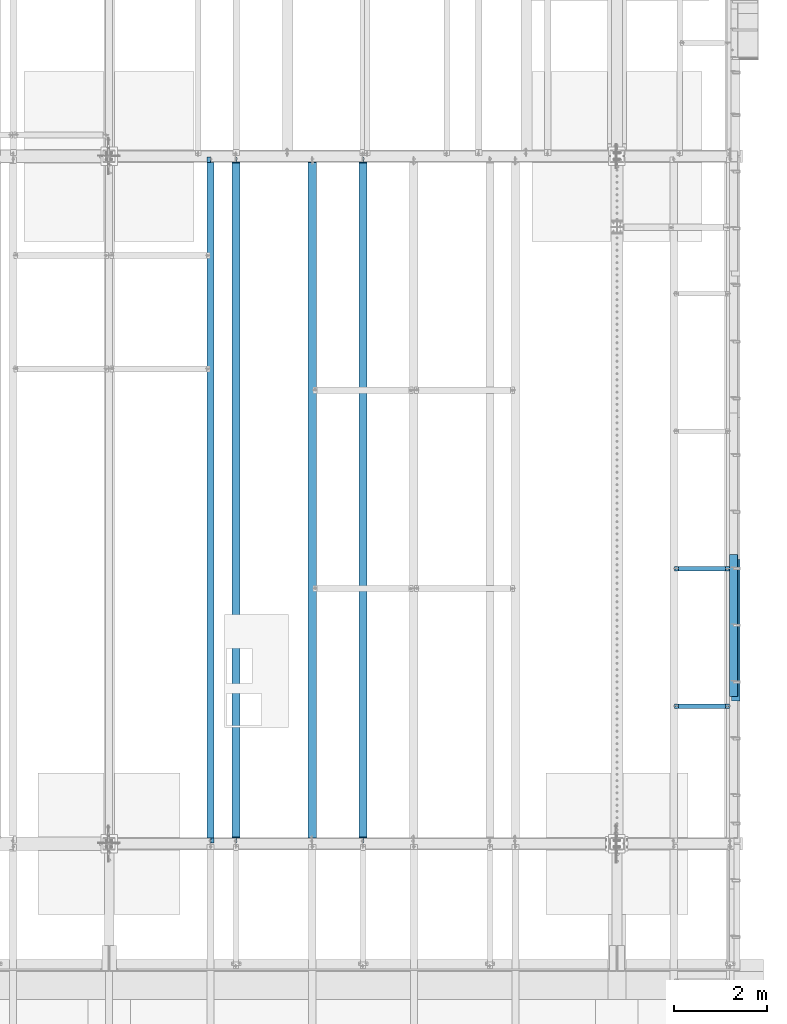
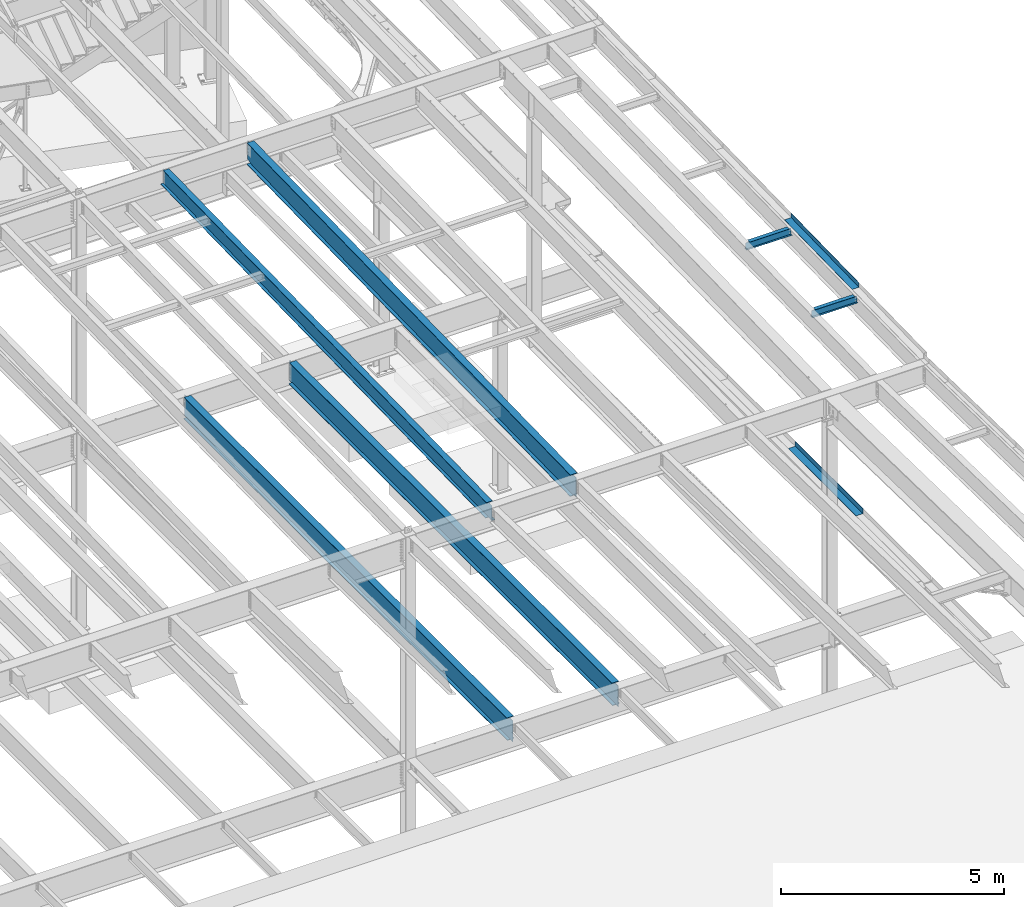
# One storey, part 1120 of 1763: 8 beams, 8 elements without a shape of their own.
"""IFC2X3 building model written with IfcOpenShell, lengths in millimetres."""

from ifc_helpers import new_model, si_unit, frame, origin_with_axes, place, context, subcontext, project, spatial, faceted_brep, material, type_object, element, aggregate, save


model = new_model("IFC2X3")

# Units and contexts
model_context = context("Model", 3, precision=1e-05, world=origin_with_axes())
body_context = subcontext(model_context, "Body", "Model", "MODEL_VIEW")
ifc_project = project(units=[si_unit("LENGTHUNIT", "METRE", prefix="MILLI"), si_unit("AREAUNIT", "SQUARE_METRE"), si_unit("VOLUMEUNIT", "CUBIC_METRE"), si_unit("MASSUNIT", "GRAM", prefix="KILO"), si_unit("TIMEUNIT", "SECOND"), si_unit("PLANEANGLEUNIT", "RADIAN"), si_unit("SOLIDANGLEUNIT", "STERADIAN"), si_unit("THERMODYNAMICTEMPERATUREUNIT", "DEGREE_CELSIUS"), si_unit("LUMINOUSINTENSITYUNIT", "LUMEN")], contexts=[model_context])

# Site, building, storey
site_placement = place(None, origin_with_axes())
site = spatial("IfcSite", under=ifc_project, at=site_placement, CompositionType="ELEMENT")
building_placement = place(site_placement, origin_with_axes())
building = spatial("IfcBuilding", under=site, at=building_placement, Name="Undefined", CompositionType="ELEMENT")
storey_placement = place(building_placement, origin_with_axes())
storey = spatial("IfcBuildingStorey", under=building, at=storey_placement, Name="Undefined", CompositionType="ELEMENT", Elevation=0.0)

# Assembly, beam
assembly_1_placement = place(storey_placement, origin_with_axes())
assembly_1 = element("IfcElementAssembly", 1, at=assembly_1_placement, inside=storey, Name="BEAM", AssemblyPlace="NOTDEFINED", PredefinedType="RIGID_FRAME")
ifc_material_1 = material(Name="STEEL/A992")
beam_type_1 = type_object("IfcBeamType", Name="W8X10", PredefinedType="NOTDEFINED")
beam_1_placement = place(assembly_1_placement, frame((-22808.6484080275, 32979.36, 11251.4577057883), z_axis=(0.0, 0.0, 1.0), x_axis=(1.0, 0.0, 0.0)))
beam_1 = element("IfcBeam", 2, at=beam_1_placement, type_object=beam_type_1, material=ifc_material_1, Name="BEAM", ObjectType="W8X10", context=body_context, shape_type="Brep", body=[
    faceted_brep([(1119.19526367187, -50.7999999999993, 100.012500000001), (1119.19526367187, -50.7999999999993, 95.25), (1119.19526367187, -2.38124999999854, 95.25), (1119.19526367187, -2.38124999999854, 83.877501483119), (1119.19526367187, 2.38124999999854, 83.877501483119), (1119.19526367187, 2.38124999999854, 95.25), (1119.19526367187, 50.7999999999993, 95.25), (1119.19526367187, 50.7999999999993, 100.012500000001), (1120.16199359446, -2.38124999999854, 79.0174219650726), (1120.16199359446, 2.38124999999854, 79.0174219650726), (1122.91500749494, -2.38124999999854, 74.8972454969189), (1122.91500749494, 2.38124999999854, 74.8972454969189), (1127.03518396309, -2.38124999999854, 72.1442315964414), (1127.03518396309, 2.38124999999854, 72.1442315964414), (1131.89526348114, -2.38124999999854, 71.1775016738538), (1131.89526348114, 2.38124999999854, 71.1775016738538), (1201.74526367187, -2.38124999999854, 71.1775016738538), (1201.74526367187, 2.38124999999854, 71.1775016738538), (100.012500000012, -50.7999999999993, 100.012500000001), (100.012500000012, 50.7999999999993, 100.012500000001), (100.012500000012, 50.7999999999993, 95.25), (100.012500000012, 2.38124999999854, 95.25), (100.012500000012, 2.38124999999854, 83.877501483119), (100.012500000012, -2.38124999999854, 83.877501483119), (100.012500000012, -2.38124999999854, 95.25), (100.012500000012, -50.7999999999993, 95.25), (99.0457700774241, 2.38124999999854, 79.0174219650726), (99.0457700774241, -2.38124999999854, 79.0174219650726), (96.2927561769466, 2.38124999999854, 74.8972454969189), (96.2927561769466, -2.38124999999854, 74.8972454969189), (92.1725797087929, 2.38124999999854, 72.1442315964414), (92.1725797087929, -2.38124999999854, 72.1442315964414), (87.3125001907465, 2.38124999999854, 71.1775016738538), (87.3125001907465, -2.38124999999854, 71.1775016738538), (17.4625000000015, 2.38124999999854, 71.1775016738538), (17.4625000000015, -2.38124999999854, 71.1775016738538), (17.462499935149, 2.38124999999854, -95.25), (17.4625000000015, 50.7999999999993, -95.25), (17.4625000000015, 50.7999999999993, -100.012500000001), (17.4624996160601, -50.8000000000029, -100.012500000001), (17.4624996160601, -50.8000000000029, -95.25), (17.4624999065727, -2.38124999999854, -95.25), (1201.74526367187, 2.38124999999854, -95.25), (1201.74526367187, 50.7999999999993, -95.25), (1201.74526367187, 50.7999999999993, -100.012500000001), (1201.74526367187, -50.7999999999993, -100.012500000001), (1201.74526367187, -50.7999999999993, -95.25), (1201.74526367187, -2.38124999999854, -95.25)], [[[0, 1, 2, 3, 4, 5, 6, 7]], [[8, 9, 4, 3]], [[10, 11, 9, 8]], [[12, 13, 11, 10]], [[14, 15, 13, 12]], [[16, 17, 15, 14]], [[18, 19, 20, 21, 22, 23, 24, 25]], [[23, 22, 26, 27]], [[27, 26, 28, 29]], [[29, 28, 30, 31]], [[31, 30, 32, 33]], [[33, 32, 34, 35]], [[36, 37, 38, 39, 40, 41, 35, 34]], [[37, 36, 42, 43]], [[38, 37, 43, 44]], [[39, 38, 44, 45]], [[40, 39, 45, 46]], [[41, 40, 46, 47]], [[12, 10, 8, 3, 2, 24, 23, 27, 29, 31, 33, 35, 41, 47, 16, 14]], [[25, 24, 2, 1]], [[18, 25, 1, 0]], [[19, 18, 0, 7]], [[20, 19, 7, 6]], [[21, 20, 6, 5]], [[42, 36, 34, 32, 30, 28, 26, 22, 21, 5, 4, 9, 11, 13, 15, 17]], [[47, 46, 45, 44, 43, 42, 17, 16]]]),
])
aggregate(assembly_1, [beam_1])

assembly_2_placement = place(storey_placement, origin_with_axes())
assembly_2 = element("IfcElementAssembly", 3, at=assembly_2_placement, inside=storey, Name="BEAM", AssemblyPlace="NOTDEFINED", PredefinedType="RIGID_FRAME")
beam_2_placement = place(assembly_2_placement, frame((-22808.6484080275, 35935.92, 11312.6279115835), z_axis=(0.0, 0.0, 1.0), x_axis=(1.0, 0.0, 0.0)))
beam_2 = element("IfcBeam", 4, at=beam_2_placement, type_object=beam_type_1, material=ifc_material_1, Name="BEAM", ObjectType="W8X10", context=body_context, shape_type="Brep", body=[
    faceted_brep([(1119.19526367187, -50.7999999999993, 100.012500000001), (1119.19526367187, -50.7999999999993, 95.25), (1119.19526367187, -2.38124999999854, 95.25), (1119.19526367187, -2.38124999999854, 83.877501483119), (1119.19526367187, 2.38124999999854, 83.877501483119), (1119.19526367187, 2.38124999999854, 95.25), (1119.19526367187, 50.7999999999993, 95.25), (1119.19526367187, 50.7999999999993, 100.012500000001), (1120.16199359446, -2.38124999999854, 79.0174219650726), (1120.16199359446, 2.38124999999854, 79.0174219650726), (1122.91500749494, -2.38124999999854, 74.8972454969189), (1122.91500749494, 2.38124999999854, 74.8972454969189), (1127.03518396309, -2.38124999999854, 72.1442315964414), (1127.03518396309, 2.38124999999854, 72.1442315964414), (1131.89526348114, -2.38124999999854, 71.1775016738538), (1131.89526348114, 2.38124999999854, 71.1775016738538), (1201.74526367187, -2.38124999999854, 71.1775016738538), (1201.74526367187, 2.38124999999854, 71.1775016738538), (100.012500000012, -50.7999999999993, 100.012500000001), (100.012500000012, 50.7999999999993, 100.012500000001), (100.012500000012, 50.7999999999993, 95.25), (100.012500000012, 2.38124999999854, 95.25), (100.012500000012, 2.38124999999854, 83.877501483119), (100.012500000012, -2.38124999999854, 83.877501483119), (100.012500000012, -2.38124999999854, 95.25), (100.012500000012, -50.7999999999993, 95.25), (99.0457700774241, 2.38124999999854, 79.0174219650726), (99.0457700774241, -2.38124999999854, 79.0174219650726), (96.2927561769466, 2.38124999999854, 74.8972454969189), (96.2927561769466, -2.38124999999854, 74.8972454969189), (92.1725797087929, 2.38124999999854, 72.1442315964414), (92.1725797087929, -2.38124999999854, 72.1442315964414), (87.3125001907465, 2.38124999999854, 71.1775016738538), (87.3125001907465, -2.38124999999854, 71.1775016738538), (17.4625000000015, 2.38124999999854, 71.1775016738538), (17.4625000000015, -2.38124999999854, 71.1775016738538), (17.462499935149, 2.38124999999854, -95.25), (17.4625000000015, 50.7999999999993, -95.25), (17.4625000000015, 50.7999999999993, -100.012500000001), (17.4624996160601, -50.8000000000029, -100.012500000001), (17.4624996160601, -50.8000000000029, -95.25), (17.4624999065727, -2.38124999999854, -95.25), (1201.74526367187, 2.38124999999854, -95.25), (1201.74526367187, 50.7999999999993, -95.25), (1201.74526367187, 50.7999999999993, -100.012500000001), (1201.74526367187, -50.7999999999993, -100.012500000001), (1201.74526367187, -50.7999999999993, -95.25), (1201.74526367187, -2.38124999999854, -95.25)], [[[0, 1, 2, 3, 4, 5, 6, 7]], [[8, 9, 4, 3]], [[10, 11, 9, 8]], [[12, 13, 11, 10]], [[14, 15, 13, 12]], [[16, 17, 15, 14]], [[18, 19, 20, 21, 22, 23, 24, 25]], [[23, 22, 26, 27]], [[27, 26, 28, 29]], [[29, 28, 30, 31]], [[31, 30, 32, 33]], [[33, 32, 34, 35]], [[36, 37, 38, 39, 40, 41, 35, 34]], [[37, 36, 42, 43]], [[38, 37, 43, 44]], [[39, 38, 44, 45]], [[40, 39, 45, 46]], [[41, 40, 46, 47]], [[12, 10, 8, 3, 2, 24, 23, 27, 29, 31, 33, 35, 41, 47, 16, 14]], [[25, 24, 2, 1]], [[18, 25, 1, 0]], [[19, 18, 0, 7]], [[20, 19, 7, 6]], [[21, 20, 6, 5]], [[42, 36, 34, 32, 30, 28, 26, 22, 21, 5, 4, 9, 11, 13, 15, 17]], [[47, 46, 45, 44, 43, 42, 17, 16]]]),
])
aggregate(assembly_2, [beam_2])

assembly_3_placement = place(storey_placement, origin_with_axes())
assembly_3 = element("IfcElementAssembly", 5, at=assembly_3_placement, inside=storey, Name="BEAM", AssemblyPlace="NOTDEFINED", PredefinedType="RIGID_FRAME")
ifc_material_2 = material(Name="STEEL/A36")
beam_type_2 = type_object("IfcBeamType", PredefinedType="NOTDEFINED")
beam_3_placement = place(assembly_3_placement, frame((-21564.0372736984, 34613.85, 5199.0625), z_axis=(0.0, -1.0, 0.0), x_axis=(1.0, 0.0, 0.0)))
beam_3 = element("IfcBeam", 6, at=beam_3_placement, type_object=beam_type_2, material=ifc_material_2, Name="BENT_PLATE", context=body_context, shape_type="Brep", body=[
    faceted_brep([(0.0, -4.76249999999982, -1524.0), (0.0, -4.76249999999982, 1524.0), (0.0, 4.76249999999982, 1524.0), (0.0, 4.76249999999982, -1524.0), (177.799996948241, 4.76249999999982, 1524.0), (177.799996948241, 4.76249999999982, -1524.0), (187.324996948242, -4.76249999999982, -1524.0), (187.324996948242, -4.76249999999982, 1524.0), (177.799996948241, 134.937496948242, 1524.0), (177.799996948241, 134.937496948242, -1524.0), (187.324996948242, 134.937496948242, 1524.0), (187.324996948242, 134.937496948242, -1524.0)], [[[0, 1, 2, 3]], [[3, 2, 4, 5]], [[1, 0, 6, 7]], [[5, 4, 8, 9]], [[4, 2, 1, 7, 10, 8]], [[7, 6, 11, 10]], [[6, 0, 3, 5, 9, 11]], [[10, 11, 9, 8]]]),
])
aggregate(assembly_3, [beam_3])

assembly_4_placement = place(storey_placement, origin_with_axes())
assembly_4 = element("IfcElementAssembly", 7, at=assembly_4_placement, inside=storey, Name="BEAM", AssemblyPlace="NOTDEFINED", PredefinedType="RIGID_FRAME")
beam_type_3 = type_object("IfcBeamType", PredefinedType="NOTDEFINED")
beam_4_placement = place(assembly_4_placement, frame((-21608.4906443556, 34715.4514095832, 11390.5650172283), z_axis=(0.0, -0.999786037781472, -0.0206852279954809), x_axis=(1.0, 0.0, 0.0)))
beam_4 = element("IfcBeam", 8, at=beam_4_placement, type_object=beam_type_3, material=ifc_material_2, Name="BENT_PLATE", context=body_context, shape_type="Brep", body=[
    faceted_brep([(0.0, -3.17499999999927, -1523.99999999999), (0.0, -3.17499999999927, 1524.0), (0.0, 3.17499999999927, 1524.0), (0.0, 3.17499999999927, -1523.99999999999), (174.625006103754, 3.17500000029031, 1523.99999999885), (174.625006103754, 3.17499999971005, -1523.99999999885), (180.975006103752, -3.17500000028485, -1523.99999999885), (180.975006103752, -3.17499999970642, 1523.99999999885), (174.625006103754, 123.824997298747, 1523.99999999882), (174.625006103754, 123.824997298168, -1523.99999999888), (180.975006103752, 123.824997298747, 1523.99999999882), (180.975006103752, 123.824997298168, -1523.99999999888)], [[[0, 1, 2, 3]], [[3, 2, 4, 5]], [[1, 0, 6, 7]], [[5, 4, 8, 9]], [[4, 2, 1, 7, 10, 8]], [[7, 6, 11, 10]], [[6, 0, 3, 5, 9, 11]], [[10, 11, 9, 8]]]),
])
aggregate(assembly_4, [beam_4])

assembly_5_placement = place(storey_placement, origin_with_axes())
assembly_5 = element("IfcElementAssembly", 9, at=assembly_5_placement, inside=storey, Name="BEAM", AssemblyPlace="NOTDEFINED", PredefinedType="RIGID_FRAME")
beam_type_4 = type_object("IfcBeamType", Name="W18X35", PredefinedType="NOTDEFINED")
beam_5_placement = place(assembly_5_placement, frame((-32765.4372736984, 30027.4629676506, 11064.9232324289), z_axis=(0.0, -0.0206852279954837, 0.999786037781472), x_axis=(0.0, 0.999786037781472, 0.0206852279954825)))
beam_5 = element("IfcBeam", 10, at=beam_5_placement, type_object=beam_type_4, material=ifc_material_1, Name="BEAM", ObjectType="W18X35", context=body_context, shape_type="Brep", body=[
    faceted_brep([(159.64619625721, 4.26867060484437, -214.312499999869), (159.646196257192, 4.26882632721026, -225.424999999859), (8.93222613264516, 4.26881713373223, -225.424999999832), (9.1621399216092, 4.26866142537256, -214.31249999984), (159.646191869044, 76.2000000000007, -214.312499999867), (159.646191869044, 76.2000000000007, -225.424999999861), (127.896191565305, -3.96875, 199.765001487393), (127.896191565305, 3.96874999999636, 199.765001487393), (126.929461642718, 3.96874999999636, 194.904921969359), (126.929461642718, -3.96875, 194.904921969359), (124.176447742248, 3.96874999999636, 190.784745501214), (124.176447742248, -3.96875, 190.784745501214), (120.056271274101, 3.96874999999636, 188.031731600742), (120.056271274101, -3.96875, 188.031731600742), (115.196191756069, 3.96874999999636, 187.065001678158), (115.196191756069, -3.96875, 187.065001678158), (17.4665018757805, 3.96874999999636, 187.065001678178), (17.4665018757805, -3.96875, 187.065001678178), (9.1621399216092, -3.96875, -214.31249999984), (14758.6054633429, -3.96875, -214.31250000265), (14766.9098252963, -3.96875, 187.065001635985), (14661.4395147718, -3.96875, 187.065001636005), (14656.5794352537, -3.96875, 188.031731558593), (14652.4592587856, -3.96875, 190.784745459065), (14649.7062448851, -3.96875, 194.904921927209), (14648.7395149625, -3.96875, 199.765001445245), (14648.7395149625, -3.96875, 214.31249999705), (127.896191565309, -3.96875, 214.312499999814), (9.1621399216092, -76.2000000000007, -214.31249999984), (14616.9895144523, -76.2000000000007, -214.312500002621), (14616.9895071152, -4.2686706132954, -214.312500002623), (14758.6054633429, -4.26865616819123, -214.31250000265), (8.93222613264516, -76.2000000000007, -225.424999999832), (14616.9895144523, -76.2000000000007, -225.425000002613), (14616.9895071152, -4.2688263315431, -225.425000002615), (14758.3755495539, -4.26881190989661, -225.42500000264), (14758.3755495539, 76.2000000000007, -225.42500000264), (14758.6054633429, 76.2000000000007, -214.31250000265), (14758.6054633429, 3.96874999999636, -214.31250000265), (14766.9098252963, 3.96874999999636, 187.065001635985), (14661.4395147718, 3.96874999999636, 187.065001636005), (14656.5794352537, 3.96874999999636, 188.031731558593), (14652.4592587856, 3.96874999999636, 190.784745459065), (14649.7062448851, 3.96874999999636, 194.904921927209), (14648.7395149625, 3.96874999999636, 199.765001445245), (14648.7395149625, -76.2000000000007, 225.424999997042), (14648.7395149625, -76.2000000000007, 214.31249999705), (14648.7395149625, 3.96874999999636, 214.31249999705), (14648.7395149625, 76.2000000000007, 214.31249999705), (14648.7395149625, 76.2000000000007, 225.424999997042), (127.896191565309, 3.96874999999636, 214.312499999814), (127.896191565309, 76.2000000000007, 214.312499999814), (127.896191565309, 76.2000000000007, 225.424999999805), (127.896191565309, -76.2000000000007, 225.424999999805), (127.896191565309, -76.2000000000007, 214.312499999814), (9.1621399216092, 3.96874999999636, -214.31249999984)], [[[0, 1, 2, 3]], [[4, 5, 1, 0]], [[6, 7, 8, 9]], [[9, 8, 10, 11]], [[11, 10, 12, 13]], [[13, 12, 14, 15]], [[15, 14, 16, 17]], [[9, 11, 13, 15, 17, 18, 19, 20, 21, 22, 23, 24, 25, 26, 27, 6]], [[19, 18, 28, 29, 30, 31]], [[28, 32, 33, 29]], [[29, 33, 34, 30]], [[31, 30, 34, 35]], [[36, 37, 38, 39, 20, 19, 31, 35]], [[20, 39, 40, 21]], [[21, 40, 41, 22]], [[22, 41, 42, 23]], [[23, 42, 43, 24]], [[24, 43, 44, 25]], [[45, 46, 26, 25, 44, 47, 48, 49]], [[48, 47, 50, 51]], [[49, 48, 51, 52]], [[45, 49, 52, 53]], [[46, 45, 53, 54]], [[26, 46, 54, 27]], [[53, 52, 51, 50, 7, 6, 27, 54]], [[47, 44, 43, 42, 41, 40, 39, 38, 55, 16, 14, 12, 10, 8, 7, 50]], [[32, 28, 18, 17, 16, 55, 3, 2]], [[36, 35, 34, 33, 32, 2, 1, 5]], [[37, 36, 5, 4]], [[55, 38, 37, 4, 0, 3]]]),
])
aggregate(assembly_5, [beam_5])

assembly_6_placement = place(storey_placement, origin_with_axes())
assembly_6 = element("IfcElementAssembly", 11, at=assembly_6_placement, inside=storey, Name="BEAM", AssemblyPlace="NOTDEFINED", PredefinedType="RIGID_FRAME")
beam_type_5 = type_object("IfcBeamType", Name="W24X55", PredefinedType="NOTDEFINED")
beam_6_placement = place(assembly_6_placement, frame((-30581.0372736984, 30029.0063442244, 10990.3266966851), z_axis=(0.0, -0.0206852279954837, 0.999786037781472), x_axis=(0.0, 0.999786037781472, 0.0206852279954825)))
beam_6 = element("IfcBeam", 12, at=beam_6_placement, type_object=beam_type_5, material=ifc_material_1, Name="BEAM", ObjectType="W24X55", context=body_context, shape_type="Brep", body=[
    faceted_brep([(14647.1958080934, -4.76250000000073, -287.337500002572), (14647.1958080934, -88.9000000000015, -287.337500002572), (14647.1958080934, -88.9000000000015, -300.03750000256), (14647.1958080934, 88.9000000000015, -300.03750000256), (14647.1958080934, 88.9000000000015, -287.337500002572), (14647.1958080934, 4.76250000000073, -287.337500002572), (14647.1958080934, 4.76250000000073, -274.897499864639), (14647.1958080934, -4.76250000000073, -274.897499864639), (14648.162538016, 4.76250000000073, -270.037420346602), (14648.162538016, -4.76250000000073, -270.037420346602), (14650.9155519165, 4.76250000000073, -265.917243878457), (14650.9155519165, -4.76250000000073, -265.917243878457), (14655.0357283846, 4.76250000000073, -263.164229977987), (14655.0357283846, -4.76250000000073, -263.164229977987), (14659.8958079027, 4.76250000000073, -262.197500055401), (14659.8958079027, -4.76250000000073, -262.197500055401), (14756.0710323529, -4.76250000000073, -262.197500055443), (14756.0710323529, 4.76250000000073, -262.197500055443), (14647.1958080935, 88.9000000000015, 287.337499996996), (14647.1958080935, 4.76250000000073, 287.337499996996), (126.352484696479, 4.76250000000073, 287.337499999761), (126.352484696479, 88.9000000000015, 287.337499999761), (126.35248469637, -4.76250000000073, -274.897499808445), (126.35248469637, 4.76250000000073, -274.897499808445), (126.35248469637, 4.76250000000073, -287.337499999807), (126.35248469637, 88.9000000000015, -287.337499999807), (126.352484696366, 88.9000000000015, -300.037499999797), (126.352484696366, -88.9000000000015, -300.037499999797), (126.35248469637, -88.9000000000015, -287.337499999807), (126.35248469637, -4.76250000000073, -287.337499999807), (125.385754773786, -4.76250000000073, -270.03742029041), (125.385754773786, 4.76250000000073, -270.03742029041), (122.632740873316, -4.76250000000073, -265.917243822267), (122.632740873316, 4.76250000000073, -265.917243822267), (118.512564405166, -4.76250000000073, -263.164229921793), (118.512564405166, 4.76250000000073, -263.164229921793), (113.652484887134, -4.76250000000073, -262.197499999205), (113.652484887134, 4.76250000000073, -262.197499999205), (6.62770893273409, -4.76250000000073, -262.197499999185), (6.62770893273409, 4.76250000000073, -262.197499999185), (17.4665018757441, -4.76250000000073, 261.677501677954), (17.4665018757441, 4.76250000000073, 261.677501677954), (113.652484887236, -4.76250000000073, 261.677501677934), (113.652484887236, 4.76250000000073, 261.677501677934), (118.512564405268, -4.76250000000073, 262.64423160052), (118.512564405268, 4.76250000000073, 262.64423160052), (122.632740873414, -4.76250000000073, 265.39724550099), (122.632740873414, 4.76250000000073, 265.39724550099), (125.385754773884, -4.76250000000073, 269.517421969134), (125.385754773884, 4.76250000000073, 269.517421969134), (126.352484696472, -4.76250000000073, 274.377501487168), (126.352484696472, 4.76250000000073, 274.377501487168), (14647.1958080935, -88.9000000000015, 300.037499996986), (14647.1958080935, 88.9000000000015, 300.037499996986), (126.352484696483, 88.9000000000015, 300.037499999753), (126.352484696483, -88.9000000000015, 300.037499999753), (14647.1958080935, -88.9000000000015, 287.337499996996), (126.352484696479, -88.9000000000015, 287.337499999761), (14647.1958080935, -4.76250000000073, 287.337499996996), (126.352484696479, -4.76250000000073, 287.337499999761), (14647.1958080935, -4.76250000000073, 274.377501430976), (14647.1958080935, 4.76250000000073, 274.377501430976), (14648.1625380161, -4.76250000000073, 269.517421912944), (14648.1625380161, 4.76250000000073, 269.517421912944), (14650.9155519166, -4.76250000000073, 265.397245444798), (14650.9155519166, 4.76250000000073, 265.397245444798), (14655.0357283847, -4.76250000000073, 262.644231544326), (14655.0357283847, 4.76250000000073, 262.644231544326), (14659.8958079028, -4.76250000000073, 261.677501621738), (14659.8958079028, 4.76250000000073, 261.677501621738), (14766.9098252959, -4.76250000000073, 261.677501621718), (14766.9098252959, 4.76250000000073, 261.677501621718)], [[[0, 1, 2, 3, 4, 5, 6, 7]], [[7, 6, 8, 9]], [[9, 8, 10, 11]], [[11, 10, 12, 13]], [[13, 12, 14, 15]], [[16, 15, 14, 17]], [[18, 19, 20, 21]], [[22, 23, 24, 25, 26, 27, 28, 29]], [[30, 31, 23, 22]], [[32, 33, 31, 30]], [[34, 35, 33, 32]], [[36, 37, 35, 34]], [[38, 39, 37, 36]], [[40, 41, 39, 38]], [[42, 43, 41, 40]], [[44, 45, 43, 42]], [[46, 47, 45, 44]], [[48, 49, 47, 46]], [[50, 51, 49, 48]], [[52, 53, 54, 55]], [[56, 52, 55, 57]], [[58, 56, 57, 59]], [[55, 54, 21, 20, 51, 50, 59, 57]], [[53, 18, 21, 54]], [[52, 56, 58, 60, 61, 19, 18, 53]], [[62, 63, 61, 60]], [[64, 65, 63, 62]], [[66, 67, 65, 64]], [[68, 69, 67, 66]], [[70, 71, 69, 68]], [[71, 70, 16, 17]], [[12, 10, 8, 6, 5, 24, 23, 31, 33, 35, 37, 39, 41, 43, 45, 47, 49, 51, 20, 19, 61, 63, 65, 67, 69, 71, 17, 14]], [[25, 24, 5, 4]], [[26, 25, 4, 3]], [[27, 26, 3, 2]], [[28, 27, 2, 1]], [[29, 28, 1, 0]], [[70, 68, 66, 64, 62, 60, 58, 59, 50, 48, 46, 44, 42, 40, 38, 36, 34, 32, 30, 22, 29, 0, 7, 9, 11, 13, 15, 16]]]),
])
aggregate(assembly_6, [beam_6])

assembly_7_placement = place(storey_placement, origin_with_axes())
assembly_7 = element("IfcElementAssembly", 13, at=assembly_7_placement, inside=storey, Name="BEAM", AssemblyPlace="NOTDEFINED", PredefinedType="RIGID_FRAME")
beam_type_6 = type_object("IfcBeamType", Name="W24X62", PredefinedType="NOTDEFINED")
beam_7_placement = place(assembly_7_placement, frame((-29488.8372736984, 30022.8, 4892.675), z_axis=(0.0, 0.0, 1.0), x_axis=(0.0, 1.0, 0.0)))
beam_7 = element("IfcBeam", 14, at=beam_7_placement, type_object=beam_type_6, material=ifc_material_1, Name="BEAM", ObjectType="W24X62", context=body_context, shape_type="Brep", body=[
    faceted_brep([(19.0500000000029, -5.85639903280753, -287.3375), (19.0500000000029, -5.85613127077522, -301.625), (120.650010332869, -5.85611918055292, -301.625), (120.65001033292, -5.85638694259978, -287.3375), (120.650020215031, -88.9000000000015, -287.3375), (120.65002021494, -88.9000000000015, -301.625), (146.050000000003, -5.55625000000146, 282.315001487731), (146.050000000003, 5.55625000000146, 282.315001487731), (145.083270077415, 5.55625000000146, 277.454921969686), (145.083270077415, -5.55625000000146, 277.454921969686), (142.330256176938, 5.55625000000146, 273.334745501532), (142.330256176938, -5.55625000000146, 273.334745501532), (138.210079708784, 5.55625000000146, 270.581731601053), (138.210079708784, -5.55625000000146, 270.581731601053), (133.350000190738, 5.55625000000146, 269.615001678466), (133.350000190738, -5.55625000000146, 269.615001678466), (19.0500000000029, 5.55625000000146, 269.615001678466), (19.0500000000029, -5.55625000000146, 269.615001678466), (19.0500000000029, -5.55625000000146, -287.3375), (14763.75, -5.55625000000146, -287.3375), (14763.75, -5.55625000000146, 269.615001678466), (14649.4499998093, -5.55625000000146, 269.615001678466), (14644.5899202912, -5.55625000000146, 270.581731601053), (14640.4697438231, -5.55625000000146, 273.334745501532), (14637.7167299226, -5.55625000000146, 277.454921969686), (14636.75, -5.55625000000146, 282.315001487731), (14636.75, -5.55625000000146, 287.3375), (146.050000000003, -5.55625000000146, 287.3375), (14763.75, 5.55625000000146, 269.615001678466), (14649.4499998093, 5.55625000000146, 269.615001678466), (14644.5899202912, 5.55625000000146, 270.581731601053), (14640.4697438231, 5.55625000000146, 273.334745501532), (14637.7167299226, 5.55625000000146, 277.454921969686), (14636.75, 5.55625000000146, 282.315001487731), (14636.75, -88.9000000000015, 301.625), (14636.75, -88.9000000000015, 287.3375), (14636.75, 5.55625000000146, 287.3375), (14636.75, 88.9000000000015, 287.3375), (14636.75, 88.9000000000015, 301.625), (146.050000000003, 5.55625000000146, 287.3375), (146.049999999999, 88.9000000000015, 287.3375), (146.050000000003, 88.9000000000015, 301.625), (146.050000000003, -88.9000000000015, 301.625), (146.049999999999, -88.9000000000015, 287.3375), (14763.75, 5.55625000000146, -287.3375), (19.0500000000029, 5.55625000000146, -287.3375), (14763.75, 5.85639903281481, -287.3375), (14662.1499896671, 5.85638694260706, -287.3375), (14662.1499797849, 88.9000000000015, -287.3375), (120.650000595357, 88.9000000000015, -287.3375), (120.650010477239, 5.85611915402842, -287.3375), (19.0500000000029, 5.85610706381703, -287.3375), (120.650010477188, 5.85638691607164, -301.625), (19.0500000000029, 5.85637482584934, -301.625), (120.650000595248, 88.9000000000015, -301.625), (14662.149979785, 88.9000000000015, -301.625), (14662.1499896671, 5.8561191805602, -301.625), (14763.75, 5.8561312707825, -301.625), (14763.75, -5.85610706381703, -287.3375), (14763.75, -5.85637482584934, -301.625), (14662.1499895228, -5.85611915402842, -287.3375), (14662.1499895228, -5.85638691607164, -301.625), (14662.1499994046, -88.9000000000015, -287.3375), (14662.1499994047, -88.9000000000015, -301.625)], [[[0, 1, 2, 3]], [[4, 3, 2, 5]], [[6, 7, 8, 9]], [[9, 8, 10, 11]], [[11, 10, 12, 13]], [[13, 12, 14, 15]], [[15, 14, 16, 17]], [[9, 11, 13, 15, 17, 18, 19, 20, 21, 22, 23, 24, 25, 26, 27, 6]], [[20, 28, 29, 21]], [[21, 29, 30, 22]], [[22, 30, 31, 23]], [[23, 31, 32, 24]], [[24, 32, 33, 25]], [[34, 35, 26, 25, 33, 36, 37, 38]], [[37, 36, 39, 40]], [[38, 37, 40, 41]], [[34, 38, 41, 42]], [[35, 34, 42, 43]], [[26, 35, 43, 27]], [[42, 41, 40, 39, 7, 6, 27, 43]], [[36, 33, 32, 31, 30, 29, 28, 44, 45, 16, 14, 12, 10, 8, 7, 39]], [[45, 44, 46, 47, 48, 49, 50, 51]], [[50, 52, 53, 51]], [[49, 54, 52, 50]], [[48, 55, 54, 49]], [[47, 56, 55, 48]], [[46, 57, 56, 47]], [[44, 28, 20, 19, 58, 59, 57, 46]], [[58, 60, 61, 59]], [[62, 63, 61, 60]], [[63, 62, 4, 5]], [[1, 53, 52, 54, 55, 56, 57, 59, 61, 63, 5, 2]], [[18, 17, 16, 45, 51, 53, 1, 0]], [[62, 60, 58, 19, 18, 0, 3, 4]]]),
])
aggregate(assembly_7, [beam_7])

assembly_8_placement = place(storey_placement, origin_with_axes())
assembly_8 = element("IfcElementAssembly", 15, at=assembly_8_placement, inside=storey, Name="BEAM", AssemblyPlace="NOTDEFINED", PredefinedType="RIGID_FRAME")
beam_8_placement = place(assembly_8_placement, frame((-32219.3372736984, 30022.8, 4892.675), z_axis=(0.0, 0.0, 1.0), x_axis=(0.0, 1.0, 0.0)))
beam_8 = element("IfcBeam", 16, at=beam_8_placement, type_object=beam_type_6, material=ifc_material_1, Name="BEAM", ObjectType="W24X62", context=body_context, shape_type="Brep", body=[
    faceted_brep([(19.0500000000029, -5.85639903280753, -287.3375), (19.0500000000029, -5.85613127077522, -301.625), (120.650010332869, -5.85611918055292, -301.625), (120.65001033292, -5.85638694259978, -287.3375), (120.650020215031, -88.9000000000015, -287.3375), (120.65002021494, -88.9000000000015, -301.625), (146.050000000003, -5.55625000000146, 282.315001487731), (146.050000000003, 5.55625000000146, 282.315001487731), (145.083270077415, 5.55625000000146, 277.454921969686), (145.083270077415, -5.55625000000146, 277.454921969686), (142.330256176938, 5.55625000000146, 273.334745501532), (142.330256176938, -5.55625000000146, 273.334745501532), (138.210079708784, 5.55625000000146, 270.581731601053), (138.210079708784, -5.55625000000146, 270.581731601053), (133.350000190738, 5.55625000000146, 269.615001678466), (133.350000190738, -5.55625000000146, 269.615001678466), (19.0500000000029, 5.55625000000146, 269.615001678466), (19.0500000000029, -5.55625000000146, 269.615001678466), (19.0500000000029, -5.55625000000146, -287.3375), (14763.75, -5.55625000000146, -287.3375), (14763.75, -5.55625000000146, 269.615001678466), (14649.4499998093, -5.55625000000146, 269.615001678466), (14644.5899202912, -5.55625000000146, 270.581731601053), (14640.4697438231, -5.55625000000146, 273.334745501532), (14637.7167299226, -5.55625000000146, 277.454921969686), (14636.75, -5.55625000000146, 282.315001487731), (14636.75, -5.55625000000146, 287.3375), (146.050000000003, -5.55625000000146, 287.3375), (14763.75, 5.55625000000146, 269.615001678466), (14649.4499998093, 5.55625000000146, 269.615001678466), (14644.5899202912, 5.55625000000146, 270.581731601053), (14640.4697438231, 5.55625000000146, 273.334745501532), (14637.7167299226, 5.55625000000146, 277.454921969686), (14636.75, 5.55625000000146, 282.315001487731), (14636.75, -88.9000000000015, 301.625), (14636.75, -88.9000000000015, 287.3375), (14636.75, 5.55625000000146, 287.3375), (14636.75, 88.9000000000015, 287.3375), (14636.75, 88.9000000000015, 301.625), (146.050000000003, 5.55625000000146, 287.3375), (146.049999999999, 88.9000000000015, 287.3375), (146.050000000003, 88.9000000000015, 301.625), (146.050000000003, -88.9000000000015, 301.625), (146.049999999999, -88.9000000000015, 287.3375), (14763.75, 5.55625000000146, -287.3375), (19.0500000000029, 5.55625000000146, -287.3375), (14763.75, 5.85639903281481, -287.3375), (14662.1499896671, 5.85638694260706, -287.3375), (14662.1499797849, 88.9000000000015, -287.3375), (120.650000595357, 88.9000000000015, -287.3375), (120.650010477239, 5.85611915402842, -287.3375), (19.0500000000029, 5.85610706381703, -287.3375), (120.650010477188, 5.85638691607164, -301.625), (19.0500000000029, 5.85637482584934, -301.625), (120.650000595248, 88.9000000000015, -301.625), (14662.149979785, 88.9000000000015, -301.625), (14662.1499896671, 5.8561191805602, -301.625), (14763.75, 5.8561312707825, -301.625), (14763.75, -5.85610706381703, -287.3375), (14763.75, -5.85637482584934, -301.625), (14662.1499895228, -5.85611915402842, -287.3375), (14662.1499895228, -5.85638691607164, -301.625), (14662.1499994046, -88.9000000000015, -287.3375), (14662.1499994047, -88.9000000000015, -301.625)], [[[0, 1, 2, 3]], [[4, 3, 2, 5]], [[6, 7, 8, 9]], [[9, 8, 10, 11]], [[11, 10, 12, 13]], [[13, 12, 14, 15]], [[15, 14, 16, 17]], [[9, 11, 13, 15, 17, 18, 19, 20, 21, 22, 23, 24, 25, 26, 27, 6]], [[20, 28, 29, 21]], [[21, 29, 30, 22]], [[22, 30, 31, 23]], [[23, 31, 32, 24]], [[24, 32, 33, 25]], [[34, 35, 26, 25, 33, 36, 37, 38]], [[37, 36, 39, 40]], [[38, 37, 40, 41]], [[34, 38, 41, 42]], [[35, 34, 42, 43]], [[26, 35, 43, 27]], [[42, 41, 40, 39, 7, 6, 27, 43]], [[36, 33, 32, 31, 30, 29, 28, 44, 45, 16, 14, 12, 10, 8, 7, 39]], [[45, 44, 46, 47, 48, 49, 50, 51]], [[50, 52, 53, 51]], [[49, 54, 52, 50]], [[48, 55, 54, 49]], [[47, 56, 55, 48]], [[46, 57, 56, 47]], [[44, 28, 20, 19, 58, 59, 57, 46]], [[58, 60, 61, 59]], [[62, 63, 61, 60]], [[63, 62, 4, 5]], [[1, 53, 52, 54, 55, 56, 57, 59, 61, 63, 5, 2]], [[18, 17, 16, 45, 51, 53, 1, 0]], [[62, 60, 58, 19, 18, 0, 3, 4]]]),
])
aggregate(assembly_8, [beam_8])

save(model, "model.ifc")
